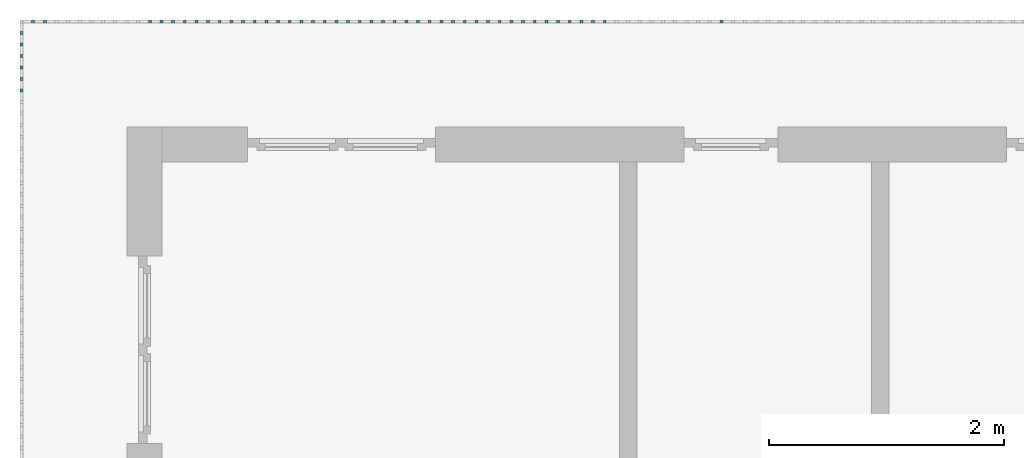
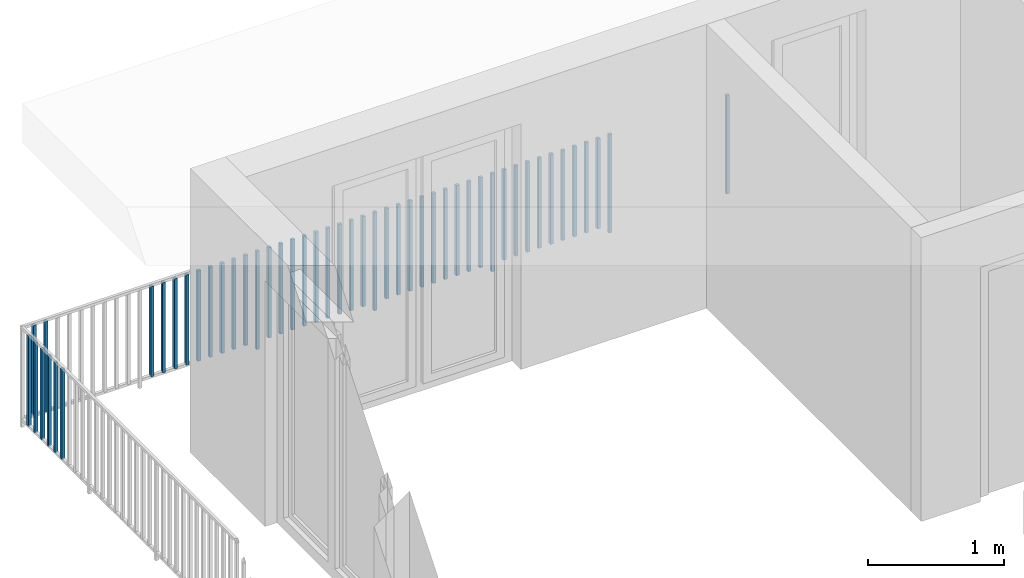
# One storey, part 48 of 54: 49 building element parts, 1 element without a shape of its own.
"""IFC4 building model written with IfcOpenShell, lengths in metres."""

import ifcopenshell
import ifcopenshell.guid

model = None  # the IFC model being written
_history = None  # IfcOwnerHistory: only IFC2X3 demands one
_inside = {}  # id of a spatial element -> (the spatial element, [elements in it])
_under = {}  # id of a project, library or spatial element -> (it, [spatial elements below it])
_declared = {}  # id of a project -> (the project, [libraries it declares])
_typed = {}  # id of a type object -> (the type object, [elements of that type])
_made_of = {}  # id of a material, layer set ... -> (it, [elements and type objects made of it])


def new_model(schema):
    """Start an empty IFC model of exactly this schema.

    Asked for "IFC4X3", IfcOpenShell would pick the latest addendum, in which some entities
    have other attributes; the version numbers below select the first issue.
    IFC2X3 requires an IfcOwnerHistory on every rooted entity: one is made here for all.
    """
    global model, _history
    if schema == "IFC4X3":
        model = ifcopenshell.file(schema_version=(4, 3, 0, 0))
    else:
        model = ifcopenshell.file(schema=schema)
    _inside.clear()
    _under.clear()
    _declared.clear()
    _typed.clear()
    _made_of.clear()
    _history = None
    if model.schema == "IFC2X3":
        org = make("IfcOrganization", Name="unknown")
        user = make(
            "IfcPersonAndOrganization",
            ThePerson=make("IfcPerson", FamilyName="unknown"),
            TheOrganization=org,
        )
        app = make(
            "IfcApplication",
            ApplicationDeveloper=org,
            Version="unknown",
            ApplicationFullName="unknown",
            ApplicationIdentifier="unknown",
        )
        _history = make(
            "IfcOwnerHistory",
            OwningUser=user,
            OwningApplication=app,
            ChangeAction="ADDED",
            CreationDate=0,
        )
    return model


def make(cls, **values):
    """One entity of the class cls with the attributes given. An attribute that is None is left unset."""
    return model.create_entity(
        cls, **{name: value for name, value in values.items() if value is not None}
    )


def entity(cls, *values):
    """Any entity or typed value of the class cls, its attributes in the order of the schema. None: left unset."""
    e = model.create_entity(cls)
    for i, value in enumerate(values):
        if value is not None:
            e[i] = value
    return e


def rooted(cls, **values):
    """An entity with a GlobalId (a new one), such as an element, a storey or a relation."""
    return make(cls, GlobalId=ifcopenshell.guid.new(), OwnerHistory=_history, **values)


def si_unit(unit_type, name, prefix=None):
    """IfcSIUnit, for example si_unit("LENGTHUNIT", "METRE", prefix="MILLI")."""
    return make("IfcSIUnit", UnitType=unit_type, Prefix=prefix, Name=name)


def converted_unit(unit_type, name, factor, base, dimensions=None, offset=None):
    """IfcConversionBasedUnit, such as the inch: factor (a typed value) times the base unit."""
    return make(
        "IfcConversionBasedUnit"
        if offset is None
        else "IfcConversionBasedUnitWithOffset",
        ConversionOffset=offset,
        Dimensions=None
        if dimensions is None
        else entity("IfcDimensionalExponents", *dimensions),
        UnitType=unit_type,
        Name=name,
        ConversionFactor=make(
            "IfcMeasureWithUnit", ValueComponent=factor, UnitComponent=base
        ),
    )


def derived_unit(unit_type, elements):
    """IfcDerivedUnit: a product of units, each with its exponent."""
    return make(
        "IfcDerivedUnit",
        Elements=[
            make("IfcDerivedUnitElement", Unit=unit, Exponent=power)
            for unit, power in elements
        ],
        UnitType=unit_type,
    )


def assignment(units):
    """IfcUnitAssignment: the units of a project."""
    return None if units is None else make("IfcUnitAssignment", Units=units)


def point(xyz):
    """IfcCartesianPoint."""
    return None if xyz is None else make("IfcCartesianPoint", Coordinates=xyz)


def direction(xyz):
    """IfcDirection."""
    return None if xyz is None else make("IfcDirection", DirectionRatios=xyz)


def frame(location, z_axis=None, x_axis=None):
    """IfcAxis2Placement3D, a coordinate frame: its origin and axes. An axis left out is left unset."""
    return make(
        "IfcAxis2Placement3D",
        Location=point(location),
        Axis=direction(z_axis),
        RefDirection=direction(x_axis),
    )


def origin_with_axes():
    """The frame at (0, 0, 0) with the z axis (0, 0, 1) and the x axis (1, 0, 0) written out."""
    return frame((0.0, 0.0, 0.0), z_axis=(0.0, 0.0, 1.0), x_axis=(1.0, 0.0, 0.0))


def place(relative_to, where):
    """IfcLocalPlacement: puts the frame where relative to a parent placement (None: the world)."""
    return make(
        "IfcLocalPlacement", PlacementRelTo=relative_to, RelativePlacement=where
    )


def context(
    kind, dimensions, precision=None, world=None, true_north=None, identifier=None
):
    """IfcGeometricRepresentationContext, for example the 3D "Model" context."""
    return make(
        "IfcGeometricRepresentationContext",
        ContextIdentifier=identifier,
        ContextType=kind,
        CoordinateSpaceDimension=dimensions,
        Precision=precision,
        WorldCoordinateSystem=world,
        TrueNorth=true_north,
    )


def subcontext(parent, identifier, kind, view, scale=None):
    """IfcGeometricRepresentationSubContext, for example "Body" below "Model"."""
    return make(
        "IfcGeometricRepresentationSubContext",
        ContextIdentifier=identifier,
        ContextType=kind,
        ParentContext=parent,
        TargetScale=scale,
        TargetView=view,
    )


def project(units=None, contexts=None):
    """IfcProject with its units and contexts."""
    return rooted(
        "IfcProject",
        Name="project",
        RepresentationContexts=contexts,
        UnitsInContext=assignment(units),
    )


def spatial(cls, under=None, at=None, **own):
    """A site, building, storey or space (cls), placed at a placement, below another one or the project."""
    s = rooted(cls, ObjectPlacement=at, **own)
    if under is not None:
        _under.setdefault(under.id(), (under, []))[1].append(s)
    return s


def point_list(points):
    """IfcCartesianPointList2D or 3D."""
    cls = (
        "IfcCartesianPointList2D" if len(points[0]) == 2 else "IfcCartesianPointList3D"
    )
    return make(cls, CoordList=points)


def polygons(points, faces, closed=None, point_numbers=None):
    """IfcPolygonalFaceSet: a face is its outer loop, then its inner loops; points numbered from 1."""
    made = []
    for loops in faces:
        if len(loops) == 1:
            made.append(make("IfcIndexedPolygonalFace", CoordIndex=loops[0]))
        else:
            made.append(
                make(
                    "IfcIndexedPolygonalFaceWithVoids",
                    CoordIndex=loops[0],
                    InnerCoordIndices=loops[1:],
                )
            )
    return make(
        "IfcPolygonalFaceSet",
        Coordinates=point_list(points),
        Closed=closed,
        Faces=made,
        PnIndex=point_numbers,
    )


def shape(context_of_items, identifier, shape_type, items):
    """IfcShapeRepresentation: the items that make up one representation, for example the "Body"."""
    return make(
        "IfcShapeRepresentation",
        ContextOfItems=context_of_items,
        RepresentationIdentifier=identifier,
        RepresentationType=shape_type,
        Items=items,
    )


def material(Name=None, Category=None):
    """IfcMaterial."""
    return make("IfcMaterial", Name=Name, Category=Category)


def made_of(thing, what):
    """Note that an element or type object is made of a material, layer set ...; save() writes the relation."""
    if what is not None:
        _made_of.setdefault(what.id(), (what, []))[1].append(thing)
    return thing


def type_object(cls, material=None, **own):
    """A type object (cls), such as IfcWallType, which elements share."""
    return made_of(rooted(cls, **own), material)


def element(
    cls,
    number,
    at=None,
    inside=None,
    cuts=None,
    type_object=None,
    material=None,
    context=None,
    identifier="Body",
    shape_type=None,
    held_by="IfcProductDefinitionShape",
    body=None,
    shapes=None,
    **own,
):
    """One element of the class cls, such as IfcWall. Its Tag is "e" and its number.

    at: its placement. inside: the storey or other place that contains it. cuts: it is an
    opening in that element (IfcRelVoidsElement). A single representation is given by context,
    identifier, shape_type and body (its items); several are given by shapes. held_by: the class
    of the entity that holds the representations. save() writes the other relations.
    """
    e = rooted(cls, Tag="e%d" % number, ObjectPlacement=at, **own)
    if body is not None:
        shapes = [shape(context, identifier, shape_type, body)]
    if shapes is not None:
        e.Representation = make(held_by, Representations=shapes)
    if inside is not None:
        _inside.setdefault(inside.id(), (inside, []))[1].append(e)
    if cuts is not None:
        rooted(
            "IfcRelVoidsElement", RelatingBuildingElement=cuts, RelatedOpeningElement=e
        )
    if type_object is not None:
        _typed.setdefault(type_object.id(), (type_object, []))[1].append(e)
    return made_of(e, material)


def aggregate(whole, parts):
    """IfcRelAggregates: a whole, such as a stair, and the parts it consists of."""
    return rooted("IfcRelAggregates", RelatingObject=whole, RelatedObjects=parts)


def save(model, path):
    """Write the relations noted so far, then the file.

    IfcRelAggregates (storeys below a building ...), IfcRelContainedInSpatialStructure (elements
    in a storey), IfcRelDefinesByType, IfcRelAssociatesMaterial and IfcRelDeclares: one each for
    every whole, place, type object, material and project.
    """
    for whole, parts in _under.values():
        aggregate(whole, parts)
    for where, things in _inside.values():
        rooted(
            "IfcRelContainedInSpatialStructure",
            RelatedElements=things,
            RelatingStructure=where,
        )
    for kind, things in _typed.values():
        rooted("IfcRelDefinesByType", RelatedObjects=things, RelatingType=kind)
    for what, things in _made_of.values():
        rooted("IfcRelAssociatesMaterial", RelatedObjects=things, RelatingMaterial=what)
    for by, libraries in _declared.values():
        rooted("IfcRelDeclares", RelatingContext=by, RelatedDefinitions=libraries)
    model.write(path)


model = new_model("IFC4")

# Units and contexts
model_context = context("Model", 3, precision=1e-05, world=origin_with_axes(), true_north=direction((0.0, 1.0)))
body_context = subcontext(model_context, "Body", "Model", "MODEL_VIEW")
ifc_project = project(units=[si_unit("LENGTHUNIT", "METRE"), si_unit("AREAUNIT", "SQUARE_METRE"), si_unit("VOLUMEUNIT", "CUBIC_METRE"), converted_unit("PLANEANGLEUNIT", "DEGREE", entity("IfcPlaneAngleMeasure", 0.0174532925199), si_unit("PLANEANGLEUNIT", "RADIAN"), dimensions=[0, 0, 0, 0, 0, 0, 0]), converted_unit("TIMEUNIT", "Year", entity("IfcTimeMeasure", 31556926.0), si_unit("TIMEUNIT", "SECOND"), dimensions=[0, 0, 1, 0, 0, 0, 0]), si_unit("MASSUNIT", "GRAM", prefix="KILO"), si_unit("THERMODYNAMICTEMPERATUREUNIT", "DEGREE_CELSIUS"), si_unit("LUMINOUSINTENSITYUNIT", "LUMEN"), si_unit("ENERGYUNIT", "JOULE", prefix="MEGA"), derived_unit("THERMALCONDUCTANCEUNIT", [(si_unit("POWERUNIT", "WATT"), 1), (si_unit("LENGTHUNIT", "METRE"), -1), (si_unit("THERMODYNAMICTEMPERATUREUNIT", "KELVIN"), -1)]), derived_unit("SPECIFICHEATCAPACITYUNIT", [(si_unit("ENERGYUNIT", "JOULE"), 1), (si_unit("MASSUNIT", "GRAM", prefix="KILO"), -1), (si_unit("THERMODYNAMICTEMPERATUREUNIT", "KELVIN"), -1)]), derived_unit("MASSDENSITYUNIT", [(si_unit("MASSUNIT", "GRAM", prefix="KILO"), 1), (si_unit("VOLUMEUNIT", "CUBIC_METRE"), -1)])], contexts=[model_context])

# Site, building, storey, space
site_placement = place(None, origin_with_axes())
site = spatial("IfcSite", under=ifc_project, at=site_placement, CompositionType="ELEMENT")
building_placement = place(site_placement, origin_with_axes())
building = spatial("IfcBuilding", under=site, at=building_placement, CompositionType="ELEMENT")
storey_placement = place(building_placement, frame((0.0, 0.0, 6.29), z_axis=(0.0, 0.0, 1.0), x_axis=(1.0, 0.0, 0.0)))
storey = spatial("IfcBuildingStorey", under=building, at=storey_placement, Name="2. Geschoss", CompositionType="ELEMENT", Elevation=6.29)
space_placement = place(storey_placement, frame((10.2378006196, 9.82118769833, 0.0), z_axis=(0.0, 0.0, 1.0), x_axis=(-1.0, 0.0, 0.0)))
space = spatial("IfcSpace", under=storey, at=space_placement, CompositionType="ELEMENT", PredefinedType="EXTERNAL")

# Railing, building element parts
railing_type = type_object("IfcRailingType", PredefinedType="NOTDEFINED")
railing_placement = place(space_placement, frame((0.0, -7.06315681498e-08, 0.0), z_axis=(0.0, 0.0, 1.0), x_axis=(-1.0, 0.0, 0.0)))
railing = element("IfcRailing", 1, at=railing_placement, inside=space, type_object=railing_type, PredefinedType="NOTDEFINED")
ifc_material = material()
building_element_part_1_placement = place(railing_placement, origin_with_axes())
building_element_part_1 = element("IfcBuildingElementPart", 2, at=building_element_part_1_placement, material=ifc_material, PredefinedType="NOTDEFINED", context=body_context, shape_type="Tessellation", body=[
    polygons([(-16.9238043478, 0.0125, 0.0), (-16.9238043478, -0.0125, 0.0), (-16.9238043478, -0.0125, 0.88), (-16.9238043478, 0.0125, 0.88), (-16.8988043478, 0.0125, 0.0), (-16.8988043478, -0.0125, 0.0), (-16.8988043478, -0.0125, 0.88), (-16.8988043478, 0.0125, 0.88)], [[[1, 2, 3, 4]], [[1, 5, 6, 2]], [[2, 6, 7, 3]], [[4, 3, 7, 8]], [[5, 1, 4, 8]], [[6, 5, 8, 7]]], closed=True),
])
building_element_part_2_placement = place(railing_placement, origin_with_axes())
building_element_part_2 = element("IfcBuildingElementPart", 3, at=building_element_part_2_placement, material=ifc_material, PredefinedType="NOTDEFINED", context=body_context, shape_type="Tessellation", body=[
    polygons([(-17.9185869565, 0.0125, 0.0), (-17.9185869565, -0.0125, 0.0), (-17.9185869565, -0.0125, 0.88), (-17.9185869565, 0.0125, 0.88), (-17.8935869565, 0.0125, 0.0), (-17.8935869565, -0.0125, 0.0), (-17.8935869565, -0.0125, 0.88), (-17.8935869565, 0.0125, 0.88)], [[[1, 2, 3, 4]], [[1, 5, 6, 2]], [[2, 6, 7, 3]], [[4, 3, 7, 8]], [[5, 1, 4, 8]], [[6, 5, 8, 7]]], closed=True),
])
building_element_part_3_placement = place(railing_placement, origin_with_axes())
building_element_part_3 = element("IfcBuildingElementPart", 4, at=building_element_part_3_placement, material=ifc_material, PredefinedType="NOTDEFINED", context=body_context, shape_type="Tessellation", body=[
    polygons([(-18.0180652174, 0.0125, 0.07), (-18.0180652174, -0.0125, 0.07), (-18.0180652174, -0.0125, 0.8775), (-18.0180652174, 0.0125, 0.8775), (-17.9930652174, 0.0125, 0.07), (-17.9930652174, -0.0125, 0.07), (-17.9930652174, -0.0125, 0.8775), (-17.9930652174, 0.0125, 0.8775)], [[[1, 2, 3, 4]], [[1, 5, 6, 2]], [[2, 6, 7, 3]], [[4, 3, 7, 8]], [[5, 1, 4, 8]], [[6, 5, 8, 7]]], closed=True),
])
building_element_part_4_placement = place(railing_placement, origin_with_axes())
building_element_part_4 = element("IfcBuildingElementPart", 5, at=building_element_part_4_placement, material=ifc_material, PredefinedType="NOTDEFINED", context=body_context, shape_type="Tessellation", body=[
    polygons([(-18.1175434783, 0.0125, 0.07), (-18.1175434783, -0.0125, 0.07), (-18.1175434783, -0.0125, 0.8775), (-18.1175434783, 0.0125, 0.8775), (-18.0925434783, 0.0125, 0.07), (-18.0925434783, -0.0125, 0.07), (-18.0925434783, -0.0125, 0.8775), (-18.0925434783, 0.0125, 0.8775)], [[[1, 2, 3, 4]], [[1, 5, 6, 2]], [[2, 6, 7, 3]], [[4, 3, 7, 8]], [[5, 1, 4, 8]], [[6, 5, 8, 7]]], closed=True),
])
building_element_part_5_placement = place(railing_placement, origin_with_axes())
building_element_part_5 = element("IfcBuildingElementPart", 6, at=building_element_part_5_placement, material=ifc_material, PredefinedType="NOTDEFINED", context=body_context, shape_type="Tessellation", body=[
    polygons([(-18.2170217391, 0.0125, 0.07), (-18.2170217391, -0.0125, 0.07), (-18.2170217391, -0.0125, 0.8775), (-18.2170217391, 0.0125, 0.8775), (-18.1920217391, 0.0125, 0.07), (-18.1920217391, -0.0125, 0.07), (-18.1920217391, -0.0125, 0.8775), (-18.1920217391, 0.0125, 0.8775)], [[[1, 2, 3, 4]], [[1, 5, 6, 2]], [[2, 6, 7, 3]], [[4, 3, 7, 8]], [[5, 1, 4, 8]], [[6, 5, 8, 7]]], closed=True),
])
building_element_part_6_placement = place(railing_placement, origin_with_axes())
building_element_part_6 = element("IfcBuildingElementPart", 7, at=building_element_part_6_placement, material=ifc_material, PredefinedType="NOTDEFINED", context=body_context, shape_type="Tessellation", body=[
    polygons([(-18.3165, 0.0125, 0.07), (-18.3165, -0.0125, 0.07), (-18.3165, -0.0125, 0.8775), (-18.3165, 0.0125, 0.8775), (-18.2915, 0.0125, 0.07), (-18.2915, -0.0125, 0.07), (-18.2915, -0.0125, 0.8775), (-18.2915, 0.0125, 0.8775)], [[[1, 2, 3, 4]], [[1, 5, 6, 2]], [[2, 6, 7, 3]], [[4, 3, 7, 8]], [[5, 1, 4, 8]], [[6, 5, 8, 7]]], closed=True),
])
building_element_part_7_placement = place(railing_placement, origin_with_axes())
building_element_part_7 = element("IfcBuildingElementPart", 8, at=building_element_part_7_placement, material=ifc_material, PredefinedType="NOTDEFINED", context=body_context, shape_type="Tessellation", body=[
    polygons([(-18.4159782609, 0.0125, 0.07), (-18.4159782609, -0.0125, 0.07), (-18.4159782609, -0.0125, 0.8775), (-18.4159782609, 0.0125, 0.8775), (-18.3909782609, 0.0125, 0.07), (-18.3909782609, -0.0125, 0.07), (-18.3909782609, -0.0125, 0.8775), (-18.3909782609, 0.0125, 0.8775)], [[[1, 2, 3, 4]], [[1, 5, 6, 2]], [[2, 6, 7, 3]], [[4, 3, 7, 8]], [[5, 1, 4, 8]], [[6, 5, 8, 7]]], closed=True),
])
building_element_part_8_placement = place(railing_placement, origin_with_axes())
building_element_part_8 = element("IfcBuildingElementPart", 9, at=building_element_part_8_placement, material=ifc_material, PredefinedType="NOTDEFINED", context=body_context, shape_type="Tessellation", body=[
    polygons([(-18.5154565217, 0.0125, 0.07), (-18.5154565217, -0.0125, 0.07), (-18.5154565217, -0.0125, 0.8775), (-18.5154565217, 0.0125, 0.8775), (-18.4904565217, 0.0125, 0.07), (-18.4904565217, -0.0125, 0.07), (-18.4904565217, -0.0125, 0.8775), (-18.4904565217, 0.0125, 0.8775)], [[[1, 2, 3, 4]], [[1, 5, 6, 2]], [[2, 6, 7, 3]], [[4, 3, 7, 8]], [[5, 1, 4, 8]], [[6, 5, 8, 7]]], closed=True),
])
building_element_part_9_placement = place(railing_placement, origin_with_axes())
building_element_part_9 = element("IfcBuildingElementPart", 10, at=building_element_part_9_placement, material=ifc_material, PredefinedType="NOTDEFINED", context=body_context, shape_type="Tessellation", body=[
    polygons([(-18.6149347826, 0.0125, 0.07), (-18.6149347826, -0.0125, 0.07), (-18.6149347826, -0.0125, 0.8775), (-18.6149347826, 0.0125, 0.8775), (-18.5899347826, 0.0125, 0.07), (-18.5899347826, -0.0125, 0.07), (-18.5899347826, -0.0125, 0.8775), (-18.5899347826, 0.0125, 0.8775)], [[[1, 2, 3, 4]], [[1, 5, 6, 2]], [[2, 6, 7, 3]], [[4, 3, 7, 8]], [[5, 1, 4, 8]], [[6, 5, 8, 7]]], closed=True),
])
building_element_part_10_placement = place(railing_placement, origin_with_axes())
building_element_part_10 = element("IfcBuildingElementPart", 11, at=building_element_part_10_placement, material=ifc_material, PredefinedType="NOTDEFINED", context=body_context, shape_type="Tessellation", body=[
    polygons([(-18.7144130435, 0.0125, 0.07), (-18.7144130435, -0.0125, 0.07), (-18.7144130435, -0.0125, 0.8775), (-18.7144130435, 0.0125, 0.8775), (-18.6894130435, 0.0125, 0.07), (-18.6894130435, -0.0125, 0.07), (-18.6894130435, -0.0125, 0.8775), (-18.6894130435, 0.0125, 0.8775)], [[[1, 2, 3, 4]], [[1, 5, 6, 2]], [[2, 6, 7, 3]], [[4, 3, 7, 8]], [[5, 1, 4, 8]], [[6, 5, 8, 7]]], closed=True),
])
building_element_part_11_placement = place(railing_placement, origin_with_axes())
building_element_part_11 = element("IfcBuildingElementPart", 12, at=building_element_part_11_placement, material=ifc_material, PredefinedType="NOTDEFINED", context=body_context, shape_type="Tessellation", body=[
    polygons([(-18.8138913043, 0.0125, 0.07), (-18.8138913043, -0.0125, 0.07), (-18.8138913043, -0.0125, 0.8775), (-18.8138913043, 0.0125, 0.8775), (-18.7888913043, 0.0125, 0.07), (-18.7888913043, -0.0125, 0.07), (-18.7888913043, -0.0125, 0.8775), (-18.7888913043, 0.0125, 0.8775)], [[[1, 2, 3, 4]], [[1, 5, 6, 2]], [[2, 6, 7, 3]], [[4, 3, 7, 8]], [[5, 1, 4, 8]], [[6, 5, 8, 7]]], closed=True),
])
building_element_part_12_placement = place(railing_placement, origin_with_axes())
building_element_part_12 = element("IfcBuildingElementPart", 13, at=building_element_part_12_placement, material=ifc_material, PredefinedType="NOTDEFINED", context=body_context, shape_type="Tessellation", body=[
    polygons([(-18.9133695652, 0.0125, 0.0), (-18.9133695652, -0.0125, 0.0), (-18.9133695652, -0.0125, 0.88), (-18.9133695652, 0.0125, 0.88), (-18.8883695652, 0.0125, 0.0), (-18.8883695652, -0.0125, 0.0), (-18.8883695652, -0.0125, 0.88), (-18.8883695652, 0.0125, 0.88)], [[[1, 2, 3, 4]], [[1, 5, 6, 2]], [[2, 6, 7, 3]], [[4, 3, 7, 8]], [[5, 1, 4, 8]], [[6, 5, 8, 7]]], closed=True),
])
building_element_part_13_placement = place(railing_placement, origin_with_axes())
building_element_part_13 = element("IfcBuildingElementPart", 14, at=building_element_part_13_placement, material=ifc_material, PredefinedType="NOTDEFINED", context=body_context, shape_type="Tessellation", body=[
    polygons([(-19.0128478261, 0.0125, 0.07), (-19.0128478261, -0.0125, 0.07), (-19.0128478261, -0.0125, 0.8775), (-19.0128478261, 0.0125, 0.8775), (-18.9878478261, 0.0125, 0.07), (-18.9878478261, -0.0125, 0.07), (-18.9878478261, -0.0125, 0.8775), (-18.9878478261, 0.0125, 0.8775)], [[[1, 2, 3, 4]], [[1, 5, 6, 2]], [[2, 6, 7, 3]], [[4, 3, 7, 8]], [[5, 1, 4, 8]], [[6, 5, 8, 7]]], closed=True),
])
building_element_part_14_placement = place(railing_placement, origin_with_axes())
building_element_part_14 = element("IfcBuildingElementPart", 15, at=building_element_part_14_placement, material=ifc_material, PredefinedType="NOTDEFINED", context=body_context, shape_type="Tessellation", body=[
    polygons([(-19.112326087, 0.0125, 0.07), (-19.112326087, -0.0125, 0.07), (-19.112326087, -0.0125, 0.8775), (-19.112326087, 0.0125, 0.8775), (-19.087326087, 0.0125, 0.07), (-19.087326087, -0.0125, 0.07), (-19.087326087, -0.0125, 0.8775), (-19.087326087, 0.0125, 0.8775)], [[[1, 2, 3, 4]], [[1, 5, 6, 2]], [[2, 6, 7, 3]], [[4, 3, 7, 8]], [[5, 1, 4, 8]], [[6, 5, 8, 7]]], closed=True),
])
building_element_part_15_placement = place(railing_placement, origin_with_axes())
building_element_part_15 = element("IfcBuildingElementPart", 16, at=building_element_part_15_placement, material=ifc_material, PredefinedType="NOTDEFINED", context=body_context, shape_type="Tessellation", body=[
    polygons([(-19.2118043478, 0.0125, 0.07), (-19.2118043478, -0.0125, 0.07), (-19.2118043478, -0.0125, 0.8775), (-19.2118043478, 0.0125, 0.8775), (-19.1868043478, 0.0125, 0.07), (-19.1868043478, -0.0125, 0.07), (-19.1868043478, -0.0125, 0.8775), (-19.1868043478, 0.0125, 0.8775)], [[[1, 2, 3, 4]], [[1, 5, 6, 2]], [[2, 6, 7, 3]], [[4, 3, 7, 8]], [[5, 1, 4, 8]], [[6, 5, 8, 7]]], closed=True),
])
building_element_part_16_placement = place(railing_placement, origin_with_axes())
building_element_part_16 = element("IfcBuildingElementPart", 17, at=building_element_part_16_placement, material=ifc_material, PredefinedType="NOTDEFINED", context=body_context, shape_type="Tessellation", body=[
    polygons([(-19.3112826087, 0.0125, 0.07), (-19.3112826087, -0.0125, 0.07), (-19.3112826087, -0.0125, 0.8775), (-19.3112826087, 0.0125, 0.8775), (-19.2862826087, 0.0125, 0.07), (-19.2862826087, -0.0125, 0.07), (-19.2862826087, -0.0125, 0.8775), (-19.2862826087, 0.0125, 0.8775)], [[[1, 2, 3, 4]], [[1, 5, 6, 2]], [[2, 6, 7, 3]], [[4, 3, 7, 8]], [[5, 1, 4, 8]], [[6, 5, 8, 7]]], closed=True),
])
building_element_part_17_placement = place(railing_placement, origin_with_axes())
building_element_part_17 = element("IfcBuildingElementPart", 18, at=building_element_part_17_placement, material=ifc_material, PredefinedType="NOTDEFINED", context=body_context, shape_type="Tessellation", body=[
    polygons([(-19.4107608696, 0.0125, 0.07), (-19.4107608696, -0.0125, 0.07), (-19.4107608696, -0.0125, 0.8775), (-19.4107608696, 0.0125, 0.8775), (-19.3857608696, 0.0125, 0.07), (-19.3857608696, -0.0125, 0.07), (-19.3857608696, -0.0125, 0.8775), (-19.3857608696, 0.0125, 0.8775)], [[[1, 2, 3, 4]], [[1, 5, 6, 2]], [[2, 6, 7, 3]], [[4, 3, 7, 8]], [[5, 1, 4, 8]], [[6, 5, 8, 7]]], closed=True),
])
building_element_part_18_placement = place(railing_placement, origin_with_axes())
building_element_part_18 = element("IfcBuildingElementPart", 19, at=building_element_part_18_placement, material=ifc_material, PredefinedType="NOTDEFINED", context=body_context, shape_type="Tessellation", body=[
    polygons([(-19.5102391304, 0.0125, 0.07), (-19.5102391304, -0.0125, 0.07), (-19.5102391304, -0.0125, 0.8775), (-19.5102391304, 0.0125, 0.8775), (-19.4852391304, 0.0125, 0.07), (-19.4852391304, -0.0125, 0.07), (-19.4852391304, -0.0125, 0.8775), (-19.4852391304, 0.0125, 0.8775)], [[[1, 2, 3, 4]], [[1, 5, 6, 2]], [[2, 6, 7, 3]], [[4, 3, 7, 8]], [[5, 1, 4, 8]], [[6, 5, 8, 7]]], closed=True),
])
building_element_part_19_placement = place(railing_placement, origin_with_axes())
building_element_part_19 = element("IfcBuildingElementPart", 20, at=building_element_part_19_placement, material=ifc_material, PredefinedType="NOTDEFINED", context=body_context, shape_type="Tessellation", body=[
    polygons([(-19.6097173913, 0.0125, 0.07), (-19.6097173913, -0.0125, 0.07), (-19.6097173913, -0.0125, 0.8775), (-19.6097173913, 0.0125, 0.8775), (-19.5847173913, 0.0125, 0.07), (-19.5847173913, -0.0125, 0.07), (-19.5847173913, -0.0125, 0.8775), (-19.5847173913, 0.0125, 0.8775)], [[[1, 2, 3, 4]], [[1, 5, 6, 2]], [[2, 6, 7, 3]], [[4, 3, 7, 8]], [[5, 1, 4, 8]], [[6, 5, 8, 7]]], closed=True),
])
building_element_part_20_placement = place(railing_placement, origin_with_axes())
building_element_part_20 = element("IfcBuildingElementPart", 21, at=building_element_part_20_placement, material=ifc_material, PredefinedType="NOTDEFINED", context=body_context, shape_type="Tessellation", body=[
    polygons([(-19.7091956522, 0.0125, 0.07), (-19.7091956522, -0.0125, 0.07), (-19.7091956522, -0.0125, 0.8775), (-19.7091956522, 0.0125, 0.8775), (-19.6841956522, 0.0125, 0.07), (-19.6841956522, -0.0125, 0.07), (-19.6841956522, -0.0125, 0.8775), (-19.6841956522, 0.0125, 0.8775)], [[[1, 2, 3, 4]], [[1, 5, 6, 2]], [[2, 6, 7, 3]], [[4, 3, 7, 8]], [[5, 1, 4, 8]], [[6, 5, 8, 7]]], closed=True),
])
building_element_part_21_placement = place(railing_placement, origin_with_axes())
building_element_part_21 = element("IfcBuildingElementPart", 22, at=building_element_part_21_placement, material=ifc_material, PredefinedType="NOTDEFINED", context=body_context, shape_type="Tessellation", body=[
    polygons([(-19.808673913, 0.0125, 0.07), (-19.808673913, -0.0125, 0.07), (-19.808673913, -0.0125, 0.8775), (-19.808673913, 0.0125, 0.8775), (-19.783673913, 0.0125, 0.07), (-19.783673913, -0.0125, 0.07), (-19.783673913, -0.0125, 0.8775), (-19.783673913, 0.0125, 0.8775)], [[[1, 2, 3, 4]], [[1, 5, 6, 2]], [[2, 6, 7, 3]], [[4, 3, 7, 8]], [[5, 1, 4, 8]], [[6, 5, 8, 7]]], closed=True),
])
building_element_part_22_placement = place(railing_placement, origin_with_axes())
building_element_part_22 = element("IfcBuildingElementPart", 23, at=building_element_part_22_placement, material=ifc_material, PredefinedType="NOTDEFINED", context=body_context, shape_type="Tessellation", body=[
    polygons([(-19.9081521739, 0.0125, 0.0), (-19.9081521739, -0.0125, 0.0), (-19.9081521739, -0.0125, 0.88), (-19.9081521739, 0.0125, 0.88), (-19.8831521739, 0.0125, 0.0), (-19.8831521739, -0.0125, 0.0), (-19.8831521739, -0.0125, 0.88), (-19.8831521739, 0.0125, 0.88)], [[[1, 2, 3, 4]], [[1, 5, 6, 2]], [[2, 6, 7, 3]], [[4, 3, 7, 8]], [[5, 1, 4, 8]], [[6, 5, 8, 7]]], closed=True),
])
building_element_part_23_placement = place(railing_placement, origin_with_axes())
building_element_part_23 = element("IfcBuildingElementPart", 24, at=building_element_part_23_placement, material=ifc_material, PredefinedType="NOTDEFINED", context=body_context, shape_type="Tessellation", body=[
    polygons([(-20.0076304348, 0.0125, 0.07), (-20.0076304348, -0.0125, 0.07), (-20.0076304348, -0.0125, 0.8775), (-20.0076304348, 0.0125, 0.8775), (-19.9826304348, 0.0125, 0.07), (-19.9826304348, -0.0125, 0.07), (-19.9826304348, -0.0125, 0.8775), (-19.9826304348, 0.0125, 0.8775)], [[[1, 2, 3, 4]], [[1, 5, 6, 2]], [[2, 6, 7, 3]], [[4, 3, 7, 8]], [[5, 1, 4, 8]], [[6, 5, 8, 7]]], closed=True),
])
building_element_part_24_placement = place(railing_placement, origin_with_axes())
building_element_part_24 = element("IfcBuildingElementPart", 25, at=building_element_part_24_placement, material=ifc_material, PredefinedType="NOTDEFINED", context=body_context, shape_type="Tessellation", body=[
    polygons([(-20.1071086957, 0.0125, 0.07), (-20.1071086957, -0.0125, 0.07), (-20.1071086957, -0.0125, 0.8775), (-20.1071086957, 0.0125, 0.8775), (-20.0821086957, 0.0125, 0.07), (-20.0821086957, -0.0125, 0.07), (-20.0821086957, -0.0125, 0.8775), (-20.0821086957, 0.0125, 0.8775)], [[[1, 2, 3, 4]], [[1, 5, 6, 2]], [[2, 6, 7, 3]], [[4, 3, 7, 8]], [[5, 1, 4, 8]], [[6, 5, 8, 7]]], closed=True),
])
building_element_part_25_placement = place(railing_placement, origin_with_axes())
building_element_part_25 = element("IfcBuildingElementPart", 26, at=building_element_part_25_placement, material=ifc_material, PredefinedType="NOTDEFINED", context=body_context, shape_type="Tessellation", body=[
    polygons([(-20.2065869565, 0.0125, 0.07), (-20.2065869565, -0.0125, 0.07), (-20.2065869565, -0.0125, 0.8775), (-20.2065869565, 0.0125, 0.8775), (-20.1815869565, 0.0125, 0.07), (-20.1815869565, -0.0125, 0.07), (-20.1815869565, -0.0125, 0.8775), (-20.1815869565, 0.0125, 0.8775)], [[[1, 2, 3, 4]], [[1, 5, 6, 2]], [[2, 6, 7, 3]], [[4, 3, 7, 8]], [[5, 1, 4, 8]], [[6, 5, 8, 7]]], closed=True),
])
building_element_part_26_placement = place(railing_placement, origin_with_axes())
building_element_part_26 = element("IfcBuildingElementPart", 27, at=building_element_part_26_placement, material=ifc_material, PredefinedType="NOTDEFINED", context=body_context, shape_type="Tessellation", body=[
    polygons([(-20.3060652174, 0.0125, 0.07), (-20.3060652174, -0.0125, 0.07), (-20.3060652174, -0.0125, 0.8775), (-20.3060652174, 0.0125, 0.8775), (-20.2810652174, 0.0125, 0.07), (-20.2810652174, -0.0125, 0.07), (-20.2810652174, -0.0125, 0.8775), (-20.2810652174, 0.0125, 0.8775)], [[[1, 2, 3, 4]], [[1, 5, 6, 2]], [[2, 6, 7, 3]], [[4, 3, 7, 8]], [[5, 1, 4, 8]], [[6, 5, 8, 7]]], closed=True),
])
building_element_part_27_placement = place(railing_placement, origin_with_axes())
building_element_part_27 = element("IfcBuildingElementPart", 28, at=building_element_part_27_placement, material=ifc_material, PredefinedType="NOTDEFINED", context=body_context, shape_type="Tessellation", body=[
    polygons([(-20.4055434783, 0.0125, 0.07), (-20.4055434783, -0.0125, 0.07), (-20.4055434783, -0.0125, 0.8775), (-20.4055434783, 0.0125, 0.8775), (-20.3805434783, 0.0125, 0.07), (-20.3805434783, -0.0125, 0.07), (-20.3805434783, -0.0125, 0.8775), (-20.3805434783, 0.0125, 0.8775)], [[[1, 2, 3, 4]], [[1, 5, 6, 2]], [[2, 6, 7, 3]], [[4, 3, 7, 8]], [[5, 1, 4, 8]], [[6, 5, 8, 7]]], closed=True),
])
building_element_part_28_placement = place(railing_placement, origin_with_axes())
building_element_part_28 = element("IfcBuildingElementPart", 29, at=building_element_part_28_placement, material=ifc_material, PredefinedType="NOTDEFINED", context=body_context, shape_type="Tessellation", body=[
    polygons([(-20.5050217391, 0.0125, 0.07), (-20.5050217391, -0.0125, 0.07), (-20.5050217391, -0.0125, 0.8775), (-20.5050217391, 0.0125, 0.8775), (-20.4800217391, 0.0125, 0.07), (-20.4800217391, -0.0125, 0.07), (-20.4800217391, -0.0125, 0.8775), (-20.4800217391, 0.0125, 0.8775)], [[[1, 2, 3, 4]], [[1, 5, 6, 2]], [[2, 6, 7, 3]], [[4, 3, 7, 8]], [[5, 1, 4, 8]], [[6, 5, 8, 7]]], closed=True),
])
building_element_part_29_placement = place(railing_placement, origin_with_axes())
building_element_part_29 = element("IfcBuildingElementPart", 30, at=building_element_part_29_placement, material=ifc_material, PredefinedType="NOTDEFINED", context=body_context, shape_type="Tessellation", body=[
    polygons([(-20.6045, 0.0125, 0.07), (-20.6045, -0.0125, 0.07), (-20.6045, -0.0125, 0.8775), (-20.6045, 0.0125, 0.8775), (-20.5795, 0.0125, 0.07), (-20.5795, -0.0125, 0.07), (-20.5795, -0.0125, 0.8775), (-20.5795, 0.0125, 0.8775)], [[[1, 2, 3, 4]], [[1, 5, 6, 2]], [[2, 6, 7, 3]], [[4, 3, 7, 8]], [[5, 1, 4, 8]], [[6, 5, 8, 7]]], closed=True),
])
building_element_part_30_placement = place(railing_placement, origin_with_axes())
building_element_part_30 = element("IfcBuildingElementPart", 31, at=building_element_part_30_placement, material=ifc_material, PredefinedType="NOTDEFINED", context=body_context, shape_type="Tessellation", body=[
    polygons([(-20.7039782609, 0.0125, 0.07), (-20.7039782609, -0.0125, 0.07), (-20.7039782609, -0.0125, 0.8775), (-20.7039782609, 0.0125, 0.8775), (-20.6789782609, 0.0125, 0.07), (-20.6789782609, -0.0125, 0.07), (-20.6789782609, -0.0125, 0.8775), (-20.6789782609, 0.0125, 0.8775)], [[[1, 2, 3, 4]], [[1, 5, 6, 2]], [[2, 6, 7, 3]], [[4, 3, 7, 8]], [[5, 1, 4, 8]], [[6, 5, 8, 7]]], closed=True),
])
building_element_part_31_placement = place(railing_placement, origin_with_axes())
building_element_part_31 = element("IfcBuildingElementPart", 32, at=building_element_part_31_placement, material=ifc_material, PredefinedType="NOTDEFINED", context=body_context, shape_type="Tessellation", body=[
    polygons([(-20.8034565217, 0.0125, 0.07), (-20.8034565217, -0.0125, 0.07), (-20.8034565217, -0.0125, 0.8775), (-20.8034565217, 0.0125, 0.8775), (-20.7784565217, 0.0125, 0.07), (-20.7784565217, -0.0125, 0.07), (-20.7784565217, -0.0125, 0.8775), (-20.7784565217, 0.0125, 0.8775)], [[[1, 2, 3, 4]], [[1, 5, 6, 2]], [[2, 6, 7, 3]], [[4, 3, 7, 8]], [[5, 1, 4, 8]], [[6, 5, 8, 7]]], closed=True),
])
building_element_part_32_placement = place(railing_placement, origin_with_axes())
building_element_part_32 = element("IfcBuildingElementPart", 33, at=building_element_part_32_placement, material=ifc_material, PredefinedType="NOTDEFINED", context=body_context, shape_type="Tessellation", body=[
    polygons([(-20.9029347826, 0.0125, 0.0), (-20.9029347826, -0.0125, 0.0), (-20.9029347826, -0.0125, 0.88), (-20.9029347826, 0.0125, 0.88), (-20.8779347826, 0.0125, 0.0), (-20.8779347826, -0.0125, 0.0), (-20.8779347826, -0.0125, 0.88), (-20.8779347826, 0.0125, 0.88)], [[[1, 2, 3, 4]], [[1, 5, 6, 2]], [[2, 6, 7, 3]], [[4, 3, 7, 8]], [[5, 1, 4, 8]], [[6, 5, 8, 7]]], closed=True),
])
building_element_part_33_placement = place(railing_placement, origin_with_axes())
building_element_part_33 = element("IfcBuildingElementPart", 34, at=building_element_part_33_placement, material=ifc_material, PredefinedType="NOTDEFINED", context=body_context, shape_type="Tessellation", body=[
    polygons([(-21.0024130435, 0.0125, 0.07), (-21.0024130435, -0.0125, 0.07), (-21.0024130435, -0.0125, 0.8775), (-21.0024130435, 0.0125, 0.8775), (-20.9774130435, 0.0125, 0.07), (-20.9774130435, -0.0125, 0.07), (-20.9774130435, -0.0125, 0.8775), (-20.9774130435, 0.0125, 0.8775)], [[[1, 2, 3, 4]], [[1, 5, 6, 2]], [[2, 6, 7, 3]], [[4, 3, 7, 8]], [[5, 1, 4, 8]], [[6, 5, 8, 7]]], closed=True),
])
building_element_part_34_placement = place(railing_placement, origin_with_axes())
building_element_part_34 = element("IfcBuildingElementPart", 35, at=building_element_part_34_placement, material=ifc_material, PredefinedType="NOTDEFINED", context=body_context, shape_type="Tessellation", body=[
    polygons([(-21.1018913043, 0.0125, 0.07), (-21.1018913043, -0.0125, 0.07), (-21.1018913043, -0.0125, 0.8775), (-21.1018913043, 0.0125, 0.8775), (-21.0768913043, 0.0125, 0.07), (-21.0768913043, -0.0125, 0.07), (-21.0768913043, -0.0125, 0.8775), (-21.0768913043, 0.0125, 0.8775)], [[[1, 2, 3, 4]], [[1, 5, 6, 2]], [[2, 6, 7, 3]], [[4, 3, 7, 8]], [[5, 1, 4, 8]], [[6, 5, 8, 7]]], closed=True),
])
building_element_part_35_placement = place(railing_placement, origin_with_axes())
building_element_part_35 = element("IfcBuildingElementPart", 36, at=building_element_part_35_placement, material=ifc_material, PredefinedType="NOTDEFINED", context=body_context, shape_type="Tessellation", body=[
    polygons([(-21.2013695652, 0.0125, 0.07), (-21.2013695652, -0.0125, 0.07), (-21.2013695652, -0.0125, 0.8775), (-21.2013695652, 0.0125, 0.8775), (-21.1763695652, 0.0125, 0.07), (-21.1763695652, -0.0125, 0.07), (-21.1763695652, -0.0125, 0.8775), (-21.1763695652, 0.0125, 0.8775)], [[[1, 2, 3, 4]], [[1, 5, 6, 2]], [[2, 6, 7, 3]], [[4, 3, 7, 8]], [[5, 1, 4, 8]], [[6, 5, 8, 7]]], closed=True),
])
building_element_part_36_placement = place(railing_placement, origin_with_axes())
building_element_part_36 = element("IfcBuildingElementPart", 37, at=building_element_part_36_placement, material=ifc_material, PredefinedType="NOTDEFINED", context=body_context, shape_type="Tessellation", body=[
    polygons([(-21.3008478261, 0.0125, 0.07), (-21.3008478261, -0.0125, 0.07), (-21.3008478261, -0.0125, 0.8775), (-21.3008478261, 0.0125, 0.8775), (-21.2758478261, 0.0125, 0.07), (-21.2758478261, -0.0125, 0.07), (-21.2758478261, -0.0125, 0.8775), (-21.2758478261, 0.0125, 0.8775)], [[[1, 2, 3, 4]], [[1, 5, 6, 2]], [[2, 6, 7, 3]], [[4, 3, 7, 8]], [[5, 1, 4, 8]], [[6, 5, 8, 7]]], closed=True),
])
building_element_part_37_placement = place(railing_placement, origin_with_axes())
building_element_part_37 = element("IfcBuildingElementPart", 38, at=building_element_part_37_placement, material=ifc_material, PredefinedType="NOTDEFINED", context=body_context, shape_type="Tessellation", body=[
    polygons([(-21.400326087, 0.0125, 0.07), (-21.400326087, -0.0125, 0.07), (-21.400326087, -0.0125, 0.8775), (-21.400326087, 0.0125, 0.8775), (-21.375326087, 0.0125, 0.07), (-21.375326087, -0.0125, 0.07), (-21.375326087, -0.0125, 0.8775), (-21.375326087, 0.0125, 0.8775)], [[[1, 2, 3, 4]], [[1, 5, 6, 2]], [[2, 6, 7, 3]], [[4, 3, 7, 8]], [[5, 1, 4, 8]], [[6, 5, 8, 7]]], closed=True),
])
building_element_part_38_placement = place(railing_placement, origin_with_axes())
building_element_part_38 = element("IfcBuildingElementPart", 39, at=building_element_part_38_placement, material=ifc_material, PredefinedType="NOTDEFINED", context=body_context, shape_type="Tessellation", body=[
    polygons([(-21.4998043478, 0.0125, 0.07), (-21.4998043478, -0.0125, 0.07), (-21.4998043478, -0.0125, 0.8775), (-21.4998043478, 0.0125, 0.8775), (-21.4748043478, 0.0125, 0.07), (-21.4748043478, -0.0125, 0.07), (-21.4748043478, -0.0125, 0.8775), (-21.4748043478, 0.0125, 0.8775)], [[[1, 2, 3, 4]], [[1, 5, 6, 2]], [[2, 6, 7, 3]], [[4, 3, 7, 8]], [[5, 1, 4, 8]], [[6, 5, 8, 7]]], closed=True),
])
building_element_part_39_placement = place(railing_placement, origin_with_axes())
building_element_part_39 = element("IfcBuildingElementPart", 40, at=building_element_part_39_placement, material=ifc_material, PredefinedType="NOTDEFINED", context=body_context, shape_type="Tessellation", body=[
    polygons([(-21.5992826087, 0.0125, 0.07), (-21.5992826087, -0.0125, 0.07), (-21.5992826087, -0.0125, 0.8775), (-21.5992826087, 0.0125, 0.8775), (-21.5742826087, 0.0125, 0.07), (-21.5742826087, -0.0125, 0.07), (-21.5742826087, -0.0125, 0.8775), (-21.5742826087, 0.0125, 0.8775)], [[[1, 2, 3, 4]], [[1, 5, 6, 2]], [[2, 6, 7, 3]], [[4, 3, 7, 8]], [[5, 1, 4, 8]], [[6, 5, 8, 7]]], closed=True),
])
building_element_part_40_placement = place(railing_placement, origin_with_axes())
building_element_part_40 = element("IfcBuildingElementPart", 41, at=building_element_part_40_placement, material=ifc_material, PredefinedType="NOTDEFINED", context=body_context, shape_type="Tessellation", body=[
    polygons([(-21.6987608696, 0.0125, 0.07), (-21.6987608696, -0.0125, 0.07), (-21.6987608696, -0.0125, 0.8775), (-21.6987608696, 0.0125, 0.8775), (-21.6737608696, 0.0125, 0.07), (-21.6737608696, -0.0125, 0.07), (-21.6737608696, -0.0125, 0.8775), (-21.6737608696, 0.0125, 0.8775)], [[[1, 2, 3, 4]], [[1, 5, 6, 2]], [[2, 6, 7, 3]], [[4, 3, 7, 8]], [[5, 1, 4, 8]], [[6, 5, 8, 7]]], closed=True),
])
building_element_part_41_placement = place(railing_placement, origin_with_axes())
building_element_part_41 = element("IfcBuildingElementPart", 42, at=building_element_part_41_placement, material=ifc_material, PredefinedType="NOTDEFINED", context=body_context, shape_type="Tessellation", body=[
    polygons([(-21.7982391304, 0.0125, 0.07), (-21.7982391304, -0.0125, 0.07), (-21.7982391304, -0.0125, 0.8775), (-21.7982391304, 0.0125, 0.8775), (-21.7732391304, 0.0125, 0.07), (-21.7732391304, -0.0125, 0.07), (-21.7732391304, -0.0125, 0.8775), (-21.7732391304, 0.0125, 0.8775)], [[[1, 2, 3, 4]], [[1, 5, 6, 2]], [[2, 6, 7, 3]], [[4, 3, 7, 8]], [[5, 1, 4, 8]], [[6, 5, 8, 7]]], closed=True),
])
building_element_part_42_placement = place(railing_placement, origin_with_axes())
building_element_part_42 = element("IfcBuildingElementPart", 43, at=building_element_part_42_placement, material=ifc_material, PredefinedType="NOTDEFINED", context=body_context, shape_type="Tessellation", body=[
    polygons([(-22.6935434783, 0.0125, 0.07), (-22.6935434783, -0.0125, 0.07), (-22.6935434783, -0.0125, 0.8775), (-22.6935434783, 0.0125, 0.8775), (-22.6685434783, 0.0125, 0.07), (-22.6685434783, -0.0125, 0.07), (-22.6685434783, -0.0125, 0.8775), (-22.6685434783, 0.0125, 0.8775)], [[[1, 2, 3, 4]], [[1, 5, 6, 2]], [[2, 6, 7, 3]], [[4, 3, 7, 8]], [[5, 1, 4, 8]], [[6, 5, 8, 7]]], closed=True),
])
building_element_part_43_placement = place(railing_placement, origin_with_axes())
building_element_part_43 = element("IfcBuildingElementPart", 44, at=building_element_part_43_placement, material=ifc_material, PredefinedType="NOTDEFINED", context=body_context, shape_type="Tessellation", body=[
    polygons([(-22.7930217391, 0.0125, 0.07), (-22.7930217391, -0.0125, 0.07), (-22.7930217391, -0.0125, 0.8775), (-22.7930217391, 0.0125, 0.8775), (-22.7680217391, 0.0125, 0.07), (-22.7680217391, -0.0125, 0.07), (-22.7680217391, -0.0125, 0.8775), (-22.7680217391, 0.0125, 0.8775)], [[[1, 2, 3, 4]], [[1, 5, 6, 2]], [[2, 6, 7, 3]], [[4, 3, 7, 8]], [[5, 1, 4, 8]], [[6, 5, 8, 7]]], closed=True),
])
building_element_part_44_placement = place(railing_placement, origin_with_axes())
building_element_part_44 = element("IfcBuildingElementPart", 45, at=building_element_part_44_placement, material=ifc_material, PredefinedType="NOTDEFINED", context=body_context, shape_type="Tessellation", body=[
    polygons([(-22.8925, -0.110833333333, 0.07), (-22.8675, -0.110833333333, 0.07), (-22.8675, -0.110833333333, 0.8775), (-22.8925, -0.110833333333, 0.8775), (-22.8925, -0.0858333333333, 0.07), (-22.8675, -0.0858333333333, 0.07), (-22.8675, -0.0858333333333, 0.8775), (-22.8925, -0.0858333333333, 0.8775)], [[[1, 2, 3, 4]], [[1, 5, 6, 2]], [[2, 6, 7, 3]], [[4, 3, 7, 8]], [[5, 1, 4, 8]], [[6, 5, 8, 7]]], closed=True),
])
building_element_part_45_placement = place(railing_placement, origin_with_axes())
building_element_part_45 = element("IfcBuildingElementPart", 46, at=building_element_part_45_placement, material=ifc_material, PredefinedType="NOTDEFINED", context=body_context, shape_type="Tessellation", body=[
    polygons([(-22.8925, -0.209166666667, 0.07), (-22.8675, -0.209166666667, 0.07), (-22.8675, -0.209166666667, 0.8775), (-22.8925, -0.209166666667, 0.8775), (-22.8925, -0.184166666667, 0.07), (-22.8675, -0.184166666667, 0.07), (-22.8675, -0.184166666667, 0.8775), (-22.8925, -0.184166666667, 0.8775)], [[[1, 2, 3, 4]], [[1, 5, 6, 2]], [[2, 6, 7, 3]], [[4, 3, 7, 8]], [[5, 1, 4, 8]], [[6, 5, 8, 7]]], closed=True),
])
building_element_part_46_placement = place(railing_placement, origin_with_axes())
building_element_part_46 = element("IfcBuildingElementPart", 47, at=building_element_part_46_placement, material=ifc_material, PredefinedType="NOTDEFINED", context=body_context, shape_type="Tessellation", body=[
    polygons([(-22.8925, -0.3075, 0.07), (-22.8675, -0.3075, 0.07), (-22.8675, -0.3075, 0.8775), (-22.8925, -0.3075, 0.8775), (-22.8925, -0.2825, 0.07), (-22.8675, -0.2825, 0.07), (-22.8675, -0.2825, 0.8775), (-22.8925, -0.2825, 0.8775)], [[[1, 2, 3, 4]], [[1, 5, 6, 2]], [[2, 6, 7, 3]], [[4, 3, 7, 8]], [[5, 1, 4, 8]], [[6, 5, 8, 7]]], closed=True),
])
building_element_part_47_placement = place(railing_placement, origin_with_axes())
building_element_part_47 = element("IfcBuildingElementPart", 48, at=building_element_part_47_placement, material=ifc_material, PredefinedType="NOTDEFINED", context=body_context, shape_type="Tessellation", body=[
    polygons([(-22.8925, -0.405833333333, 0.07), (-22.8675, -0.405833333333, 0.07), (-22.8675, -0.405833333333, 0.8775), (-22.8925, -0.405833333333, 0.8775), (-22.8925, -0.380833333333, 0.07), (-22.8675, -0.380833333333, 0.07), (-22.8675, -0.380833333333, 0.8775), (-22.8925, -0.380833333333, 0.8775)], [[[1, 2, 3, 4]], [[1, 5, 6, 2]], [[2, 6, 7, 3]], [[4, 3, 7, 8]], [[5, 1, 4, 8]], [[6, 5, 8, 7]]], closed=True),
])
building_element_part_48_placement = place(railing_placement, origin_with_axes())
building_element_part_48 = element("IfcBuildingElementPart", 49, at=building_element_part_48_placement, material=ifc_material, PredefinedType="NOTDEFINED", context=body_context, shape_type="Tessellation", body=[
    polygons([(-22.8925, -0.504166666667, 0.07), (-22.8675, -0.504166666667, 0.07), (-22.8675, -0.504166666667, 0.8775), (-22.8925, -0.504166666667, 0.8775), (-22.8925, -0.479166666667, 0.07), (-22.8675, -0.479166666667, 0.07), (-22.8675, -0.479166666667, 0.8775), (-22.8925, -0.479166666667, 0.8775)], [[[1, 2, 3, 4]], [[1, 5, 6, 2]], [[2, 6, 7, 3]], [[4, 3, 7, 8]], [[5, 1, 4, 8]], [[6, 5, 8, 7]]], closed=True),
])
building_element_part_49_placement = place(railing_placement, origin_with_axes())
building_element_part_49 = element("IfcBuildingElementPart", 50, at=building_element_part_49_placement, material=ifc_material, PredefinedType="NOTDEFINED", context=body_context, shape_type="Tessellation", body=[
    polygons([(-22.8925, -0.6025, 0.07), (-22.8675, -0.6025, 0.07), (-22.8675, -0.6025, 0.8775), (-22.8925, -0.6025, 0.8775), (-22.8925, -0.5775, 0.07), (-22.8675, -0.5775, 0.07), (-22.8675, -0.5775, 0.8775), (-22.8925, -0.5775, 0.8775)], [[[1, 2, 3, 4]], [[1, 5, 6, 2]], [[2, 6, 7, 3]], [[4, 3, 7, 8]], [[5, 1, 4, 8]], [[6, 5, 8, 7]]], closed=True),
])
aggregate(railing, [building_element_part_1, building_element_part_2, building_element_part_3, building_element_part_4, building_element_part_5, building_element_part_6, building_element_part_7, building_element_part_8, building_element_part_9, building_element_part_10, building_element_part_11, building_element_part_12, building_element_part_13, building_element_part_14, building_element_part_15, building_element_part_16, building_element_part_17, building_element_part_18, building_element_part_19, building_element_part_20, building_element_part_21, building_element_part_22, building_element_part_23, building_element_part_24, building_element_part_25, building_element_part_26, building_element_part_27, building_element_part_28, building_element_part_29, building_element_part_30, building_element_part_31, building_element_part_32, building_element_part_33, building_element_part_34, building_element_part_35, building_element_part_36, building_element_part_37, building_element_part_38, building_element_part_39, building_element_part_40, building_element_part_41, building_element_part_42, building_element_part_43, building_element_part_44, building_element_part_45, building_element_part_46, building_element_part_47, building_element_part_48, building_element_part_49])

save(model, "model.ifc")
